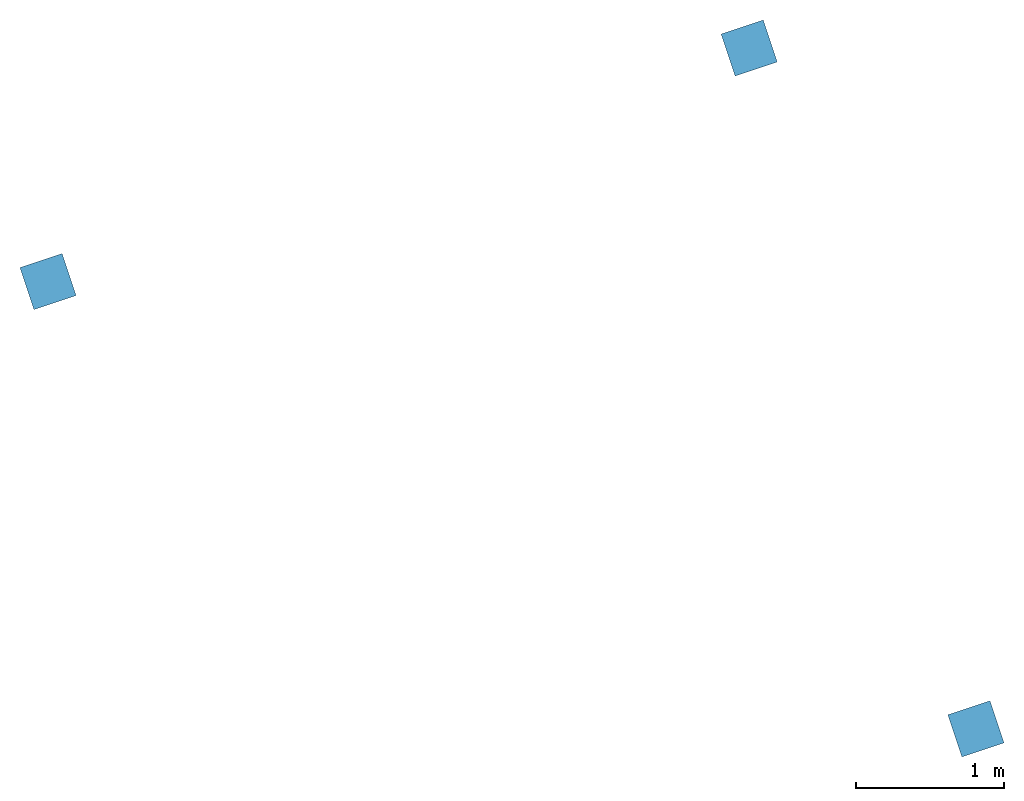
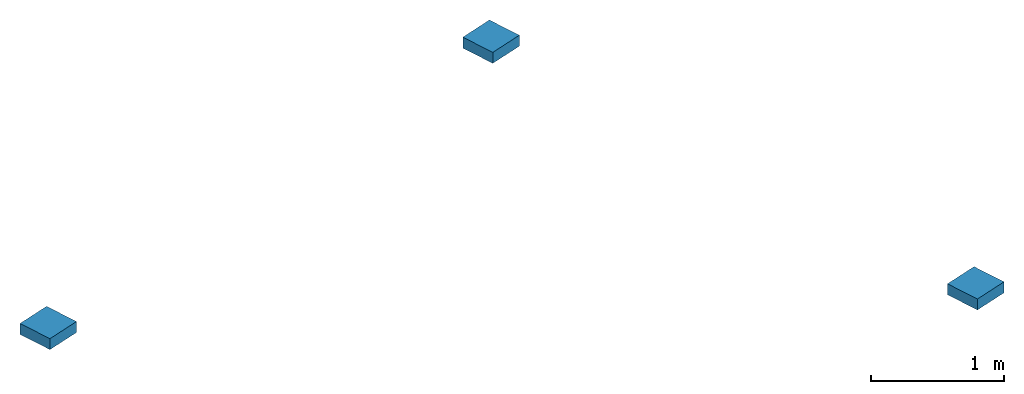
# One storey: 3 columns.
"""IFC2X3 building model written with IfcOpenShell, lengths in metres."""

import ifcopenshell
import ifcopenshell.guid

model = None  # the IFC model being written
_history = None  # IfcOwnerHistory: only IFC2X3 demands one
_inside = {}  # id of a spatial element -> (the spatial element, [elements in it])
_under = {}  # id of a project, library or spatial element -> (it, [spatial elements below it])
_declared = {}  # id of a project -> (the project, [libraries it declares])
_typed = {}  # id of a type object -> (the type object, [elements of that type])
_made_of = {}  # id of a material, layer set ... -> (it, [elements and type objects made of it])


def new_model(schema):
    """Start an empty IFC model of exactly this schema.

    Asked for "IFC4X3", IfcOpenShell would pick the latest addendum, in which some entities
    have other attributes; the version numbers below select the first issue.
    IFC2X3 requires an IfcOwnerHistory on every rooted entity: one is made here for all.
    """
    global model, _history
    if schema == "IFC4X3":
        model = ifcopenshell.file(schema_version=(4, 3, 0, 0))
    else:
        model = ifcopenshell.file(schema=schema)
    _inside.clear()
    _under.clear()
    _declared.clear()
    _typed.clear()
    _made_of.clear()
    _history = None
    if model.schema == "IFC2X3":
        org = make("IfcOrganization", Name="unknown")
        user = make(
            "IfcPersonAndOrganization",
            ThePerson=make("IfcPerson", FamilyName="unknown"),
            TheOrganization=org,
        )
        app = make(
            "IfcApplication",
            ApplicationDeveloper=org,
            Version="unknown",
            ApplicationFullName="unknown",
            ApplicationIdentifier="unknown",
        )
        _history = make(
            "IfcOwnerHistory",
            OwningUser=user,
            OwningApplication=app,
            ChangeAction="ADDED",
            CreationDate=0,
        )
    return model


def make(cls, **values):
    """One entity of the class cls with the attributes given. An attribute that is None is left unset."""
    return model.create_entity(
        cls, **{name: value for name, value in values.items() if value is not None}
    )


def entity(cls, *values):
    """Any entity or typed value of the class cls, its attributes in the order of the schema. None: left unset."""
    e = model.create_entity(cls)
    for i, value in enumerate(values):
        if value is not None:
            e[i] = value
    return e


def rooted(cls, **values):
    """An entity with a GlobalId (a new one), such as an element, a storey or a relation."""
    return make(cls, GlobalId=ifcopenshell.guid.new(), OwnerHistory=_history, **values)


def si_unit(unit_type, name, prefix=None):
    """IfcSIUnit, for example si_unit("LENGTHUNIT", "METRE", prefix="MILLI")."""
    return make("IfcSIUnit", UnitType=unit_type, Prefix=prefix, Name=name)


def converted_unit(unit_type, name, factor, base, dimensions=None, offset=None):
    """IfcConversionBasedUnit, such as the inch: factor (a typed value) times the base unit."""
    return make(
        "IfcConversionBasedUnit"
        if offset is None
        else "IfcConversionBasedUnitWithOffset",
        ConversionOffset=offset,
        Dimensions=None
        if dimensions is None
        else entity("IfcDimensionalExponents", *dimensions),
        UnitType=unit_type,
        Name=name,
        ConversionFactor=make(
            "IfcMeasureWithUnit", ValueComponent=factor, UnitComponent=base
        ),
    )


def derived_unit(unit_type, elements):
    """IfcDerivedUnit: a product of units, each with its exponent."""
    return make(
        "IfcDerivedUnit",
        Elements=[
            make("IfcDerivedUnitElement", Unit=unit, Exponent=power)
            for unit, power in elements
        ],
        UnitType=unit_type,
    )


def assignment(units):
    """IfcUnitAssignment: the units of a project."""
    return None if units is None else make("IfcUnitAssignment", Units=units)


def point(xyz):
    """IfcCartesianPoint."""
    return None if xyz is None else make("IfcCartesianPoint", Coordinates=xyz)


def direction(xyz):
    """IfcDirection."""
    return None if xyz is None else make("IfcDirection", DirectionRatios=xyz)


def frame(location, z_axis=None, x_axis=None):
    """IfcAxis2Placement3D, a coordinate frame: its origin and axes. An axis left out is left unset."""
    return make(
        "IfcAxis2Placement3D",
        Location=point(location),
        Axis=direction(z_axis),
        RefDirection=direction(x_axis),
    )


def frame_2d(location, x_axis=None):
    """IfcAxis2Placement2D, a coordinate frame in the plane: its origin and x axis."""
    return make(
        "IfcAxis2Placement2D", Location=point(location), RefDirection=direction(x_axis)
    )


def origin():
    """The frame at (0, 0, 0) with its axes left unset."""
    return frame((0.0, 0.0, 0.0))


def origin_2d_with_axis():
    """The frame at (0, 0) in the plane with the x axis (1, 0) written out."""
    return frame_2d((0.0, 0.0), x_axis=(1.0, 0.0))


def place(relative_to, where):
    """IfcLocalPlacement: puts the frame where relative to a parent placement (None: the world)."""
    return make(
        "IfcLocalPlacement", PlacementRelTo=relative_to, RelativePlacement=where
    )


def context(
    kind, dimensions, precision=None, world=None, true_north=None, identifier=None
):
    """IfcGeometricRepresentationContext, for example the 3D "Model" context."""
    return make(
        "IfcGeometricRepresentationContext",
        ContextIdentifier=identifier,
        ContextType=kind,
        CoordinateSpaceDimension=dimensions,
        Precision=precision,
        WorldCoordinateSystem=world,
        TrueNorth=true_north,
    )


def subcontext(parent, identifier, kind, view, scale=None):
    """IfcGeometricRepresentationSubContext, for example "Body" below "Model"."""
    return make(
        "IfcGeometricRepresentationSubContext",
        ContextIdentifier=identifier,
        ContextType=kind,
        ParentContext=parent,
        TargetScale=scale,
        TargetView=view,
    )


def project(units=None, contexts=None):
    """IfcProject with its units and contexts."""
    return rooted(
        "IfcProject",
        Name="project",
        RepresentationContexts=contexts,
        UnitsInContext=assignment(units),
    )


def spatial(cls, under=None, at=None, **own):
    """A site, building, storey or space (cls), placed at a placement, below another one or the project."""
    s = rooted(cls, ObjectPlacement=at, **own)
    if under is not None:
        _under.setdefault(under.id(), (under, []))[1].append(s)
    return s


def profile(cls, at=None, kind="AREA", **sizes):
    """A parametric profile (cls). Its sizes go by their IFC names, for example OverallWidth=200.0."""
    return make(cls, ProfileType=kind, Position=at, **sizes)


def rectangle(**sizes):
    """IfcRectangleProfileDef."""
    return profile("IfcRectangleProfileDef", **sizes)


def extrude(swept, where, along, depth):
    """IfcExtrudedAreaSolid: the profile swept, set in the frame where, extruded along a direction by depth."""
    return make(
        "IfcExtrudedAreaSolid",
        SweptArea=swept,
        Position=where,
        ExtrudedDirection=direction(along),
        Depth=depth,
    )


def shape(context_of_items, identifier, shape_type, items):
    """IfcShapeRepresentation: the items that make up one representation, for example the "Body"."""
    return make(
        "IfcShapeRepresentation",
        ContextOfItems=context_of_items,
        RepresentationIdentifier=identifier,
        RepresentationType=shape_type,
        Items=items,
    )


def source(mapping_origin, context_of_items, identifier, shape_type, items):
    """IfcRepresentationMap: a shape defined once, which mapped items show again and again."""
    return make(
        "IfcRepresentationMap",
        MappingOrigin=mapping_origin,
        MappedRepresentation=shape(context_of_items, identifier, shape_type, items),
    )


def transform(
    local_origin,
    x_axis=None,
    y_axis=None,
    z_axis=None,
    scale=None,
    scale2=None,
    scale3=None,
    uniform=True,
):
    """IfcCartesianTransformationOperator3D, or its non-uniform kind. x_axis, y_axis, z_axis: its Axis1, 2, 3."""
    if uniform:
        return make(
            "IfcCartesianTransformationOperator3D",
            Axis1=direction(x_axis),
            Axis2=direction(y_axis),
            LocalOrigin=point(local_origin),
            Scale=scale,
            Axis3=direction(z_axis),
        )
    return make(
        "IfcCartesianTransformationOperator3DnonUniform",
        Axis1=direction(x_axis),
        Axis2=direction(y_axis),
        LocalOrigin=point(local_origin),
        Scale=scale,
        Axis3=direction(z_axis),
        Scale2=scale2,
        Scale3=scale3,
    )


def mapped(mapping_source, mapping_target):
    """IfcMappedItem: shows the shape of a source again, moved by a transform."""
    return make(
        "IfcMappedItem", MappingSource=mapping_source, MappingTarget=mapping_target
    )


def material(Name=None, Category=None):
    """IfcMaterial."""
    return make("IfcMaterial", Name=Name, Category=Category)


def made_of(thing, what):
    """Note that an element or type object is made of a material, layer set ...; save() writes the relation."""
    if what is not None:
        _made_of.setdefault(what.id(), (what, []))[1].append(thing)
    return thing


def type_object(cls, material=None, **own):
    """A type object (cls), such as IfcWallType, which elements share."""
    return made_of(rooted(cls, **own), material)


def type_shapes(of_type, sources):
    """Give a type object the sources (RepresentationMaps) that its elements show as mapped items."""
    of_type.RepresentationMaps = sources


def element(
    cls,
    number,
    at=None,
    inside=None,
    cuts=None,
    type_object=None,
    material=None,
    context=None,
    identifier="Body",
    shape_type=None,
    held_by="IfcProductDefinitionShape",
    body=None,
    shapes=None,
    **own,
):
    """One element of the class cls, such as IfcWall. Its Tag is "e" and its number.

    at: its placement. inside: the storey or other place that contains it. cuts: it is an
    opening in that element (IfcRelVoidsElement). A single representation is given by context,
    identifier, shape_type and body (its items); several are given by shapes. held_by: the class
    of the entity that holds the representations. save() writes the other relations.
    """
    e = rooted(cls, Tag="e%d" % number, ObjectPlacement=at, **own)
    if body is not None:
        shapes = [shape(context, identifier, shape_type, body)]
    if shapes is not None:
        e.Representation = make(held_by, Representations=shapes)
    if inside is not None:
        _inside.setdefault(inside.id(), (inside, []))[1].append(e)
    if cuts is not None:
        rooted(
            "IfcRelVoidsElement", RelatingBuildingElement=cuts, RelatedOpeningElement=e
        )
    if type_object is not None:
        _typed.setdefault(type_object.id(), (type_object, []))[1].append(e)
    return made_of(e, material)


def aggregate(whole, parts):
    """IfcRelAggregates: a whole, such as a stair, and the parts it consists of."""
    return rooted("IfcRelAggregates", RelatingObject=whole, RelatedObjects=parts)


def save(model, path):
    """Write the relations noted so far, then the file.

    IfcRelAggregates (storeys below a building ...), IfcRelContainedInSpatialStructure (elements
    in a storey), IfcRelDefinesByType, IfcRelAssociatesMaterial and IfcRelDeclares: one each for
    every whole, place, type object, material and project.
    """
    for whole, parts in _under.values():
        aggregate(whole, parts)
    for where, things in _inside.values():
        rooted(
            "IfcRelContainedInSpatialStructure",
            RelatedElements=things,
            RelatingStructure=where,
        )
    for kind, things in _typed.values():
        rooted("IfcRelDefinesByType", RelatedObjects=things, RelatingType=kind)
    for what, things in _made_of.values():
        rooted("IfcRelAssociatesMaterial", RelatedObjects=things, RelatingMaterial=what)
    for by, libraries in _declared.values():
        rooted("IfcRelDeclares", RelatingContext=by, RelatedDefinitions=libraries)
    model.write(path)


model = new_model("IFC2X3")

# Units and contexts
model_context = context("Model", 3, precision=1e-05, world=origin(), true_north=direction((6.123031769111886e-17, 1.0)))
body_context = subcontext(model_context, "Body", "Model", "MODEL_VIEW")
ifc_project = project(units=[si_unit("LENGTHUNIT", "METRE"), si_unit("AREAUNIT", "SQUARE_METRE"), si_unit("VOLUMEUNIT", "CUBIC_METRE"), converted_unit("PLANEANGLEUNIT", "DEGREE", entity("IfcRatioMeasure", 0.017453292519943278), si_unit("PLANEANGLEUNIT", "RADIAN"), dimensions=[0, 0, 0, 0, 0, 0, 0]), si_unit("MASSUNIT", "GRAM", prefix="KILO"), derived_unit("MASSDENSITYUNIT", [(si_unit("MASSUNIT", "GRAM", prefix="KILO"), 1), (si_unit("LENGTHUNIT", "METRE"), -3)]), derived_unit("IONCONCENTRATIONUNIT", [(si_unit("MASSUNIT", "GRAM", prefix="KILO"), 1), (si_unit("LENGTHUNIT", "METRE"), -3)]), derived_unit("MOMENTOFINERTIAUNIT", [(si_unit("LENGTHUNIT", "METRE"), 4)]), si_unit("TIMEUNIT", "SECOND"), si_unit("FREQUENCYUNIT", "HERTZ"), si_unit("THERMODYNAMICTEMPERATUREUNIT", "DEGREE_CELSIUS"), derived_unit("THERMALTRANSMITTANCEUNIT", [(si_unit("MASSUNIT", "GRAM", prefix="KILO"), 1), (si_unit("THERMODYNAMICTEMPERATUREUNIT", "KELVIN"), -1), (si_unit("TIMEUNIT", "SECOND"), -3)]), derived_unit("THERMALCONDUCTANCEUNIT", [(si_unit("MASSUNIT", "GRAM", prefix="KILO"), 1), (si_unit("THERMODYNAMICTEMPERATUREUNIT", "KELVIN"), -1), (si_unit("TIMEUNIT", "SECOND"), -3), (si_unit("LENGTHUNIT", "METRE"), 1)]), derived_unit("VOLUMETRICFLOWRATEUNIT", [(si_unit("LENGTHUNIT", "METRE"), 3), (si_unit("TIMEUNIT", "SECOND"), -1)]), derived_unit("MASSFLOWRATEUNIT", [(si_unit("MASSUNIT", "GRAM", prefix="KILO"), 1), (si_unit("TIMEUNIT", "SECOND"), -1)]), derived_unit("ROTATIONALFREQUENCYUNIT", [(si_unit("TIMEUNIT", "SECOND"), -1)]), si_unit("ELECTRICCURRENTUNIT", "AMPERE"), si_unit("ELECTRICVOLTAGEUNIT", "VOLT"), si_unit("POWERUNIT", "WATT"), si_unit("FORCEUNIT", "NEWTON", prefix="KILO"), si_unit("ILLUMINANCEUNIT", "LUX"), si_unit("LUMINOUSFLUXUNIT", "LUMEN"), si_unit("LUMINOUSINTENSITYUNIT", "CANDELA"), derived_unit("USERDEFINED", [(si_unit("MASSUNIT", "GRAM", prefix="KILO"), -1), (si_unit("LENGTHUNIT", "METRE"), -2), (si_unit("TIMEUNIT", "SECOND"), 3), (si_unit("LUMINOUSFLUXUNIT", "LUMEN"), 1)]), derived_unit("USERDEFINED", [(si_unit("MASSUNIT", "GRAM", prefix="KILO"), 1), (si_unit("TIMEUNIT", "SECOND"), -3), (si_unit("LENGTHUNIT", "METRE"), 3), (si_unit("ELECTRICCURRENTUNIT", "AMPERE"), -2)]), derived_unit("SOUNDPOWERUNIT", [(si_unit("MASSUNIT", "GRAM", prefix="KILO"), 1), (si_unit("TIMEUNIT", "SECOND"), -3), (si_unit("LENGTHUNIT", "METRE"), 2)]), derived_unit("SOUNDPRESSUREUNIT", [(si_unit("MASSUNIT", "GRAM", prefix="KILO"), 1), (si_unit("LENGTHUNIT", "METRE"), -1), (si_unit("TIMEUNIT", "SECOND"), -2)]), derived_unit("LINEARVELOCITYUNIT", [(si_unit("LENGTHUNIT", "METRE"), 1), (si_unit("TIMEUNIT", "SECOND"), -1)]), si_unit("PRESSUREUNIT", "PASCAL"), derived_unit("USERDEFINED", [(si_unit("MASSUNIT", "GRAM", prefix="KILO"), 1), (si_unit("LENGTHUNIT", "METRE"), -2), (si_unit("TIMEUNIT", "SECOND"), -2)]), derived_unit("LINEARFORCEUNIT", [(si_unit("MASSUNIT", "GRAM", prefix="KILO"), 1), (si_unit("TIMEUNIT", "SECOND"), -2)]), derived_unit("PLANARFORCEUNIT", [(si_unit("MASSUNIT", "GRAM", prefix="KILO"), 1), (si_unit("LENGTHUNIT", "METRE"), -1), (si_unit("TIMEUNIT", "SECOND"), -2)]), derived_unit("SPECIFICHEATCAPACITYUNIT", [(si_unit("THERMODYNAMICTEMPERATUREUNIT", "KELVIN"), -1), (si_unit("LENGTHUNIT", "METRE"), 2), (si_unit("TIMEUNIT", "SECOND"), -2)]), derived_unit("HEATINGVALUEUNIT", [(si_unit("LENGTHUNIT", "METRE"), 2), (si_unit("TIMEUNIT", "SECOND"), -2)]), derived_unit("VAPORPERMEABILITYUNIT", [(si_unit("LENGTHUNIT", "METRE"), -1), (si_unit("TIMEUNIT", "SECOND"), 1)]), derived_unit("DYNAMICVISCOSITYUNIT", [(si_unit("MASSUNIT", "GRAM", prefix="KILO"), 1), (si_unit("TIMEUNIT", "SECOND"), -1), (si_unit("LENGTHUNIT", "METRE"), -1)]), derived_unit("THERMALEXPANSIONCOEFFICIENTUNIT", [(si_unit("THERMODYNAMICTEMPERATUREUNIT", "KELVIN"), -1)]), derived_unit("MODULUSOFELASTICITYUNIT", [(si_unit("MASSUNIT", "GRAM", prefix="KILO"), 1), (si_unit("LENGTHUNIT", "METRE"), -1), (si_unit("TIMEUNIT", "SECOND"), -2)]), derived_unit("ISOTHERMALMOISTURECAPACITYUNIT", [(si_unit("LENGTHUNIT", "METRE"), 3), (si_unit("MASSUNIT", "GRAM", prefix="KILO"), -1)]), derived_unit("MOISTUREDIFFUSIVITYUNIT", [(si_unit("TIMEUNIT", "SECOND"), -1), (si_unit("LENGTHUNIT", "METRE"), 2)])], contexts=[model_context])

# Site, building, storey
site_placement = place(None, frame((83.18260837531514, 5.722313863433043, -0.3219974716737357), z_axis=(0.0, 0.0, 1.0), x_axis=(0.31599863684750407, -0.9487596436982969, 0.0)))
site = spatial("IfcSite", under=ifc_project, at=site_placement, CompositionType="ELEMENT")
building_placement = place(site_placement, origin())
building = spatial("IfcBuilding", under=site, at=building_placement, CompositionType="ELEMENT")
storey_placement = place(building_placement, frame((0.0, 0.0, 3.6019974716737093)))
storey = spatial("IfcBuildingStorey", under=building, at=storey_placement, Name="Top level beton plafond RDC", CompositionType="ELEMENT", Elevation=3.6019974716737093)

# Columns
ifc_material = material(Name="Concrete - Cast-in-Place Concrete")
column_type = type_object("IfcColumnType", Name="Concrete Square:300 x 300mm", PredefinedType="COLUMN", material=ifc_material)
shared_shape = source(origin(), body_context, "Body", "SweptSolid", [
    extrude(rectangle(XDim=0.2999999999999999, YDim=0.2999999999999999, at=origin_2d_with_axis()), frame((0.0, 0.0, 3.6019974716737093), z_axis=(0.0, 0.0, 1.0), x_axis=(0.0, -1.0, 0.0)), (0.0, 0.0, 1.0), 0.10000000000000325),
])
type_shapes(column_type, [shared_shape])
for number, where, name in (
    (1, (37.32673029678136, -67.95251745260795, -3.6019974716737093), "Concrete Square:300 x 300mm"),
    (2, (42.18176797403518, -62.95251745260785, -3.6019974716737093), "Concrete Square:300 x 300mm"),
    (3, (37.32671459036835, -62.95251745260784, -3.6019974716737093), "Concrete Square:300 x 300mm"),
):
    element("IfcColumn", number, at=place(storey_placement, frame(where)), inside=storey, type_object=column_type, material=ifc_material, Name=name, ObjectType="Concrete Square:300 x 300mm", context=body_context, shape_type="MappedRepresentation", body=[
        mapped(shared_shape, transform((0.0, 0.0, 0.0), scale=1.0)),
    ])

save(model, "model.ifc")
